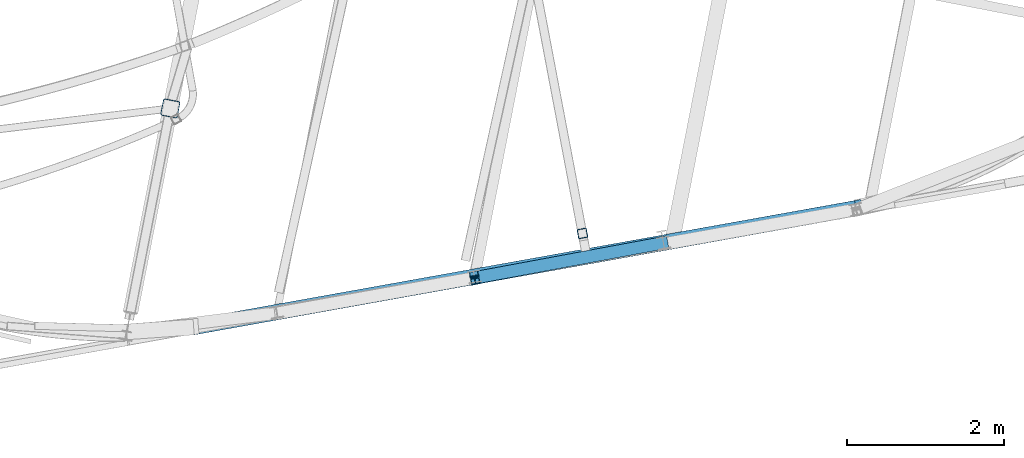
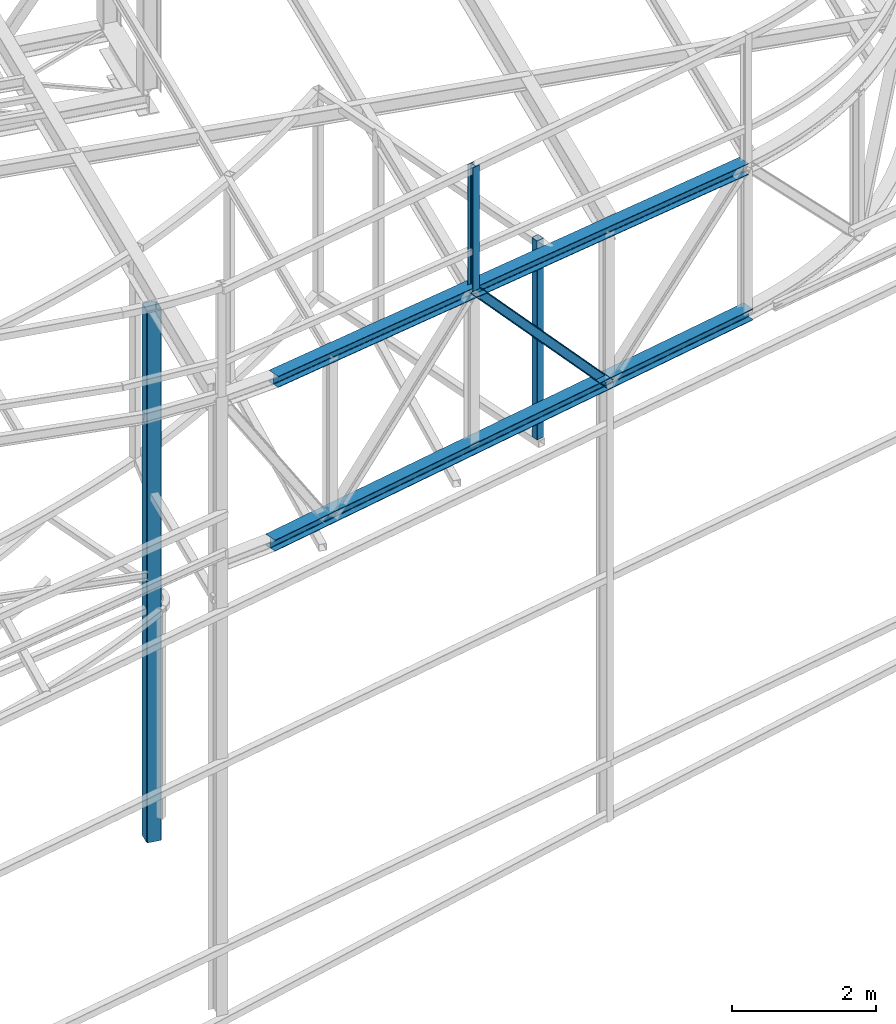
# One storey, part 55 of 215: 5 beams, 1 member, 6 elements without a shape of their own.
"""IFC2X3 building model written with IfcOpenShell, lengths in millimetres."""

import ifcopenshell
import ifcopenshell.guid

model = None  # the IFC model being written
_history = None  # IfcOwnerHistory: only IFC2X3 demands one
_inside = {}  # id of a spatial element -> (the spatial element, [elements in it])
_under = {}  # id of a project, library or spatial element -> (it, [spatial elements below it])
_declared = {}  # id of a project -> (the project, [libraries it declares])
_typed = {}  # id of a type object -> (the type object, [elements of that type])
_made_of = {}  # id of a material, layer set ... -> (it, [elements and type objects made of it])


def new_model(schema):
    """Start an empty IFC model of exactly this schema.

    Asked for "IFC4X3", IfcOpenShell would pick the latest addendum, in which some entities
    have other attributes; the version numbers below select the first issue.
    IFC2X3 requires an IfcOwnerHistory on every rooted entity: one is made here for all.
    """
    global model, _history
    if schema == "IFC4X3":
        model = ifcopenshell.file(schema_version=(4, 3, 0, 0))
    else:
        model = ifcopenshell.file(schema=schema)
    _inside.clear()
    _under.clear()
    _declared.clear()
    _typed.clear()
    _made_of.clear()
    _history = None
    if model.schema == "IFC2X3":
        org = make("IfcOrganization", Name="unknown")
        user = make(
            "IfcPersonAndOrganization",
            ThePerson=make("IfcPerson", FamilyName="unknown"),
            TheOrganization=org,
        )
        app = make(
            "IfcApplication",
            ApplicationDeveloper=org,
            Version="unknown",
            ApplicationFullName="unknown",
            ApplicationIdentifier="unknown",
        )
        _history = make(
            "IfcOwnerHistory",
            OwningUser=user,
            OwningApplication=app,
            ChangeAction="ADDED",
            CreationDate=0,
        )
    return model


def make(cls, **values):
    """One entity of the class cls with the attributes given. An attribute that is None is left unset."""
    return model.create_entity(
        cls, **{name: value for name, value in values.items() if value is not None}
    )


def rooted(cls, **values):
    """An entity with a GlobalId (a new one), such as an element, a storey or a relation."""
    return make(cls, GlobalId=ifcopenshell.guid.new(), OwnerHistory=_history, **values)


def si_unit(unit_type, name, prefix=None):
    """IfcSIUnit, for example si_unit("LENGTHUNIT", "METRE", prefix="MILLI")."""
    return make("IfcSIUnit", UnitType=unit_type, Prefix=prefix, Name=name)


def assignment(units):
    """IfcUnitAssignment: the units of a project."""
    return None if units is None else make("IfcUnitAssignment", Units=units)


def point(xyz):
    """IfcCartesianPoint."""
    return None if xyz is None else make("IfcCartesianPoint", Coordinates=xyz)


def direction(xyz):
    """IfcDirection."""
    return None if xyz is None else make("IfcDirection", DirectionRatios=xyz)


def frame(location, z_axis=None, x_axis=None):
    """IfcAxis2Placement3D, a coordinate frame: its origin and axes. An axis left out is left unset."""
    return make(
        "IfcAxis2Placement3D",
        Location=point(location),
        Axis=direction(z_axis),
        RefDirection=direction(x_axis),
    )


def frame_2d(location, x_axis=None):
    """IfcAxis2Placement2D, a coordinate frame in the plane: its origin and x axis."""
    return make(
        "IfcAxis2Placement2D", Location=point(location), RefDirection=direction(x_axis)
    )


def origin_with_axes():
    """The frame at (0, 0, 0) with the z axis (0, 0, 1) and the x axis (1, 0, 0) written out."""
    return frame((0.0, 0.0, 0.0), z_axis=(0.0, 0.0, 1.0), x_axis=(1.0, 0.0, 0.0))


def origin_2d_with_axis():
    """The frame at (0, 0) in the plane with the x axis (1, 0) written out."""
    return frame_2d((0.0, 0.0), x_axis=(1.0, 0.0))


def place(relative_to, where):
    """IfcLocalPlacement: puts the frame where relative to a parent placement (None: the world)."""
    return make(
        "IfcLocalPlacement", PlacementRelTo=relative_to, RelativePlacement=where
    )


def context(
    kind, dimensions, precision=None, world=None, true_north=None, identifier=None
):
    """IfcGeometricRepresentationContext, for example the 3D "Model" context."""
    return make(
        "IfcGeometricRepresentationContext",
        ContextIdentifier=identifier,
        ContextType=kind,
        CoordinateSpaceDimension=dimensions,
        Precision=precision,
        WorldCoordinateSystem=world,
        TrueNorth=true_north,
    )


def subcontext(parent, identifier, kind, view, scale=None):
    """IfcGeometricRepresentationSubContext, for example "Body" below "Model"."""
    return make(
        "IfcGeometricRepresentationSubContext",
        ContextIdentifier=identifier,
        ContextType=kind,
        ParentContext=parent,
        TargetScale=scale,
        TargetView=view,
    )


def project(units=None, contexts=None):
    """IfcProject with its units and contexts."""
    return rooted(
        "IfcProject",
        Name="project",
        RepresentationContexts=contexts,
        UnitsInContext=assignment(units),
    )


def spatial(cls, under=None, at=None, **own):
    """A site, building, storey or space (cls), placed at a placement, below another one or the project."""
    s = rooted(cls, ObjectPlacement=at, **own)
    if under is not None:
        _under.setdefault(under.id(), (under, []))[1].append(s)
    return s


def profile(cls, at=None, kind="AREA", **sizes):
    """A parametric profile (cls). Its sizes go by their IFC names, for example OverallWidth=200.0."""
    return make(cls, ProfileType=kind, Position=at, **sizes)


def hollow_rectangle(**sizes):
    """IfcRectangleHollowProfileDef."""
    return profile("IfcRectangleHollowProfileDef", **sizes)


def i_section(**sizes):
    """IfcIShapeProfileDef."""
    return profile("IfcIShapeProfileDef", **sizes)


def extrude(swept, where, along, depth):
    """IfcExtrudedAreaSolid: the profile swept, set in the frame where, extruded along a direction by depth."""
    return make(
        "IfcExtrudedAreaSolid",
        SweptArea=swept,
        Position=where,
        ExtrudedDirection=direction(along),
        Depth=depth,
    )


def clip(a, b, op="DIFFERENCE"):
    """IfcBooleanClippingResult: the solid a cut by the half space b."""
    return make(
        "IfcBooleanClippingResult", Operator=op, FirstOperand=a, SecondOperand=b
    )


def halfspace(plane, agree):
    """IfcHalfSpaceSolid: all space on one side of the plane z = 0 of the frame plane."""
    return make(
        "IfcHalfSpaceSolid",
        BaseSurface=make("IfcPlane", Position=plane),
        AgreementFlag=agree,
    )


def shape(context_of_items, identifier, shape_type, items):
    """IfcShapeRepresentation: the items that make up one representation, for example the "Body"."""
    return make(
        "IfcShapeRepresentation",
        ContextOfItems=context_of_items,
        RepresentationIdentifier=identifier,
        RepresentationType=shape_type,
        Items=items,
    )


def material(Name=None, Category=None):
    """IfcMaterial."""
    return make("IfcMaterial", Name=Name, Category=Category)


def made_of(thing, what):
    """Note that an element or type object is made of a material, layer set ...; save() writes the relation."""
    if what is not None:
        _made_of.setdefault(what.id(), (what, []))[1].append(thing)
    return thing


def type_object(cls, material=None, **own):
    """A type object (cls), such as IfcWallType, which elements share."""
    return made_of(rooted(cls, **own), material)


def element(
    cls,
    number,
    at=None,
    inside=None,
    cuts=None,
    type_object=None,
    material=None,
    context=None,
    identifier="Body",
    shape_type=None,
    held_by="IfcProductDefinitionShape",
    body=None,
    shapes=None,
    **own,
):
    """One element of the class cls, such as IfcWall. Its Tag is "e" and its number.

    at: its placement. inside: the storey or other place that contains it. cuts: it is an
    opening in that element (IfcRelVoidsElement). A single representation is given by context,
    identifier, shape_type and body (its items); several are given by shapes. held_by: the class
    of the entity that holds the representations. save() writes the other relations.
    """
    e = rooted(cls, Tag="e%d" % number, ObjectPlacement=at, **own)
    if body is not None:
        shapes = [shape(context, identifier, shape_type, body)]
    if shapes is not None:
        e.Representation = make(held_by, Representations=shapes)
    if inside is not None:
        _inside.setdefault(inside.id(), (inside, []))[1].append(e)
    if cuts is not None:
        rooted(
            "IfcRelVoidsElement", RelatingBuildingElement=cuts, RelatedOpeningElement=e
        )
    if type_object is not None:
        _typed.setdefault(type_object.id(), (type_object, []))[1].append(e)
    return made_of(e, material)


def aggregate(whole, parts):
    """IfcRelAggregates: a whole, such as a stair, and the parts it consists of."""
    return rooted("IfcRelAggregates", RelatingObject=whole, RelatedObjects=parts)


def save(model, path):
    """Write the relations noted so far, then the file.

    IfcRelAggregates (storeys below a building ...), IfcRelContainedInSpatialStructure (elements
    in a storey), IfcRelDefinesByType, IfcRelAssociatesMaterial and IfcRelDeclares: one each for
    every whole, place, type object, material and project.
    """
    for whole, parts in _under.values():
        aggregate(whole, parts)
    for where, things in _inside.values():
        rooted(
            "IfcRelContainedInSpatialStructure",
            RelatedElements=things,
            RelatingStructure=where,
        )
    for kind, things in _typed.values():
        rooted("IfcRelDefinesByType", RelatedObjects=things, RelatingType=kind)
    for what, things in _made_of.values():
        rooted("IfcRelAssociatesMaterial", RelatedObjects=things, RelatingMaterial=what)
    for by, libraries in _declared.values():
        rooted("IfcRelDeclares", RelatingContext=by, RelatedDefinitions=libraries)
    model.write(path)


model = new_model("IFC2X3")

# Units and contexts
model_context = context("Model", 3, precision=1e-05, world=origin_with_axes())
body_context = subcontext(model_context, "Body", "Model", "MODEL_VIEW")
ifc_project = project(units=[si_unit("LENGTHUNIT", "METRE", prefix="MILLI"), si_unit("AREAUNIT", "SQUARE_METRE"), si_unit("VOLUMEUNIT", "CUBIC_METRE"), si_unit("MASSUNIT", "GRAM", prefix="KILO"), si_unit("TIMEUNIT", "SECOND"), si_unit("PLANEANGLEUNIT", "RADIAN"), si_unit("SOLIDANGLEUNIT", "STERADIAN"), si_unit("THERMODYNAMICTEMPERATUREUNIT", "DEGREE_CELSIUS"), si_unit("LUMINOUSINTENSITYUNIT", "LUMEN")], contexts=[model_context])

# Site, building, storey
site_placement = place(None, origin_with_axes())
site = spatial("IfcSite", under=ifc_project, at=site_placement, CompositionType="ELEMENT")
building_placement = place(site_placement, origin_with_axes())
building = spatial("IfcBuilding", under=site, at=building_placement, Name="Undefined", CompositionType="ELEMENT")
storey_placement = place(building_placement, origin_with_axes())
storey = spatial("IfcBuildingStorey", under=building, at=storey_placement, Name="Undefined", CompositionType="ELEMENT", Elevation=0.0)

# Assembly, beam
assembly_1_placement = place(storey_placement, origin_with_axes())
assembly_1 = element("IfcElementAssembly", 1, at=assembly_1_placement, inside=storey, Name="Steel Assembly", AssemblyPlace="NOTDEFINED", PredefinedType="RIGID_FRAME")
ifc_material = material(Name="STEEL/S275JR")
beam_type_1 = type_object("IfcBeamType", PredefinedType="NOTDEFINED")
beam_1_placement = place(assembly_1_placement, frame((89988.6066214401, 3037.60806190424, 12139.7338379649), z_axis=(0.18677670603023, -0.982402393158983, 6.00000021319612e-09), x_axis=(0.0, 0.0, -1.0)))
beam_1 = element("IfcBeam", 2, at=beam_1_placement, type_object=beam_type_1, material=ifc_material, Name="LISSE", context=body_context, shape_type="SweptSolid", body=[
    extrude(hollow_rectangle(XDim=120.0, YDim=120.0, WallThickness=5.0, InnerFilletRadius=5.0, OuterFilletRadius=10.0, at=origin_2d_with_axis()), frame((3373.73305251272, -1.11627462918715e-20, -2.79068657296787e-21), z_axis=(-1.0, 0.0, 0.0), x_axis=(-6.93889390390723e-18, -1.0, -3.46944695195361e-18)), (0.0, 0.0, 1.0), 3373.7),
])
aggregate(assembly_1, [beam_1])

assembly_2_placement = place(storey_placement, origin_with_axes())
assembly_2 = element("IfcElementAssembly", 3, at=assembly_2_placement, inside=storey, Name="Steel Assembly", AssemblyPlace="NOTDEFINED", PredefinedType="RIGID_FRAME")
beam_type_2 = type_object("IfcBeamType", Name="HEA200", PredefinedType="NOTDEFINED")
beam_2_placement = place(assembly_2_placement, frame((85011.3616193614, 1839.94463969168, 9436.9929471351), z_axis=(-4.16799999832007e-06, 2.32339999935293e-05, 0.999999999721405), x_axis=(0.984292809071937, 0.176543666012903, 0.0)))
beam_2 = element("IfcBeam", 4, at=beam_2_placement, type_object=beam_type_2, material=ifc_material, Name="LISSE", ObjectType="HEA200", context=body_context, shape_type="SweptSolid", body=[
    extrude(i_section(OverallWidth=200.0, OverallDepth=190.0, WebThickness=6.5, FlangeThickness=10.0, FilletRadius=18.0, at=origin_2d_with_axis()), frame((8685.81424668555, -2.41079774107188e-13, -7.35717084067345e-18), z_axis=(-1.0, 0.0, 0.0), x_axis=(-6.93889390390723e-18, -1.0, -3.46944695195361e-18)), (0.0, 0.0, 1.0), 8685.8),
])
aggregate(assembly_2, [beam_2])

assembly_3_placement = place(storey_placement, origin_with_axes())
assembly_3 = element("IfcElementAssembly", 5, at=assembly_3_placement, inside=storey, Name="Steel Assembly", AssemblyPlace="NOTDEFINED", PredefinedType="RIGID_FRAME")
beam_3_placement = place(assembly_3_placement, frame((85069.4201979422, 1850.51503800022, 12187.2830973289), z_axis=(0.028777846010214, 0.00496094600176118, 0.999573521354873), x_axis=(0.983888379647059, 0.176382875936728, -0.0292016689895248)))
beam_3 = element("IfcBeam", 6, at=beam_3_placement, type_object=beam_type_2, material=ifc_material, Name="LISSE", ObjectType="HEA200", context=body_context, shape_type="SweptSolid", body=[
    extrude(i_section(OverallWidth=200.0, OverallDepth=190.0, WebThickness=6.5, FlangeThickness=10.0, FilletRadius=18.0, at=origin_2d_with_axis()), frame((8548.25270584548, -2.08907295198489e-12, -1.78933169425103e-12), z_axis=(-1.0, 0.0, 0.0), x_axis=(-6.93889390390723e-18, -1.0, -3.46944695195361e-18)), (0.0, 0.0, 1.0), 8548.3),
])
aggregate(assembly_3, [beam_3])

assembly_4_placement = place(storey_placement, origin_with_axes())
assembly_4 = element("IfcElementAssembly", 7, at=assembly_4_placement, inside=storey, Name="Steel Assembly", AssemblyPlace="NOTDEFINED", PredefinedType="RIGID_FRAME")
beam_type_3 = type_object("IfcBeamType", Name="HEA120", PredefinedType="NOTDEFINED")
beam_4_placement = place(assembly_4_placement, frame((88615.7303032137, 2442.03052241619, 14219.9939907283), z_axis=(-0.171057152954684, 0.985261107738978, -1.00000033827083e-09), x_axis=(0.0, 0.0, -1.0)))
beam_4 = element("IfcBeam", 8, at=beam_4_placement, type_object=beam_type_3, material=ifc_material, ObjectType="HEA120", context=body_context, shape_type="Clipping", body=[
    clip(extrude(i_section(OverallWidth=120.0, OverallDepth=114.0, WebThickness=5.0, FlangeThickness=8.0, FilletRadius=12.0, at=origin_2d_with_axis()), frame((2098.43144164297, -5.42431814155864e-23, -1.81898940354586e-12), z_axis=(-1.0, 0.0, 0.0), x_axis=(-6.93889390390723e-18, -1.0, -3.46944695195361e-18)), (0.0, 0.0, 1.0), 2098.4), halfspace(frame((2038.98327398898, 95.5609052993968, -57.8728926761723), z_axis=(9.84292725699121e-10, -0.00557150682891776, -0.999984479035378), x_axis=(1.0, 0.0, 0.0)), False)),
])
aggregate(assembly_4, [beam_4])

# Assembly, member
assembly_5_placement = place(storey_placement, origin_with_axes())
assembly_5 = element("IfcElementAssembly", 9, at=assembly_5_placement, inside=storey, Name="Steel Assembly", AssemblyPlace="NOTDEFINED", PredefinedType="RIGID_FRAME")
member_type = type_object("IfcMemberType", Name="HEA160", PredefinedType="NOTDEFINED")
member_placement = place(assembly_5_placement, frame((88610.7585416708, 2469.6751376104, 12111.711211159), z_axis=(0.727821319001554, 0.134904568000289, 0.67236663000144), x_axis=(0.661058232996636, 0.122796317999375, -0.740218262996234)))
member = element("IfcMember", 10, at=member_placement, type_object=member_type, material=ifc_material, Name="LISSE", ObjectType="HEA160", context=body_context, shape_type="SweptSolid", body=[
    extrude(i_section(OverallWidth=160.0, OverallDepth=152.0, WebThickness=6.0, FlangeThickness=9.0, FilletRadius=15.0, at=origin_2d_with_axis()), frame((3648.9545387662, -3.6044499744777e-12, 0.0), z_axis=(-1.0, 0.0, 0.0), x_axis=(-6.93889390390723e-18, -1.0, -3.46944695195361e-18)), (0.0, 0.0, 1.0), 3649.0),
])
aggregate(assembly_5, [member])

# Assembly, beam
assembly_6_placement = place(storey_placement, origin_with_axes())
assembly_6 = element("IfcElementAssembly", 11, at=assembly_6_placement, inside=storey, Name="Steel Assembly", AssemblyPlace="NOTDEFINED", PredefinedType="RIGID_FRAME")
beam_type_4 = type_object("IfcBeamType", PredefinedType="NOTDEFINED")
beam_5_placement = place(assembly_6_placement, frame((84723.822637615, 4634.3105788355, 11858.2644865792), z_axis=(0.191859470081235, 0.981422408415534, 0.0), x_axis=(0.0, 0.0, -1.0)))
beam_5 = element("IfcBeam", 12, at=beam_5_placement, type_object=beam_type_4, material=ifc_material, Name="POTEAU", context=body_context, shape_type="SweptSolid", body=[
    extrude(hollow_rectangle(XDim=220.0, YDim=220.0, WallThickness=10.0, InnerFilletRadius=15.0, OuterFilletRadius=25.0, at=origin_2d_with_axis()), frame((9008.26658211035, 0.0, 0.0), z_axis=(-1.0, 0.0, 0.0), x_axis=(-6.93889390390723e-18, -1.0, -3.46944695195361e-18)), (0.0, 0.0, 1.0), 9008.3),
])
aggregate(assembly_6, [beam_5])

save(model, "model.ifc")
